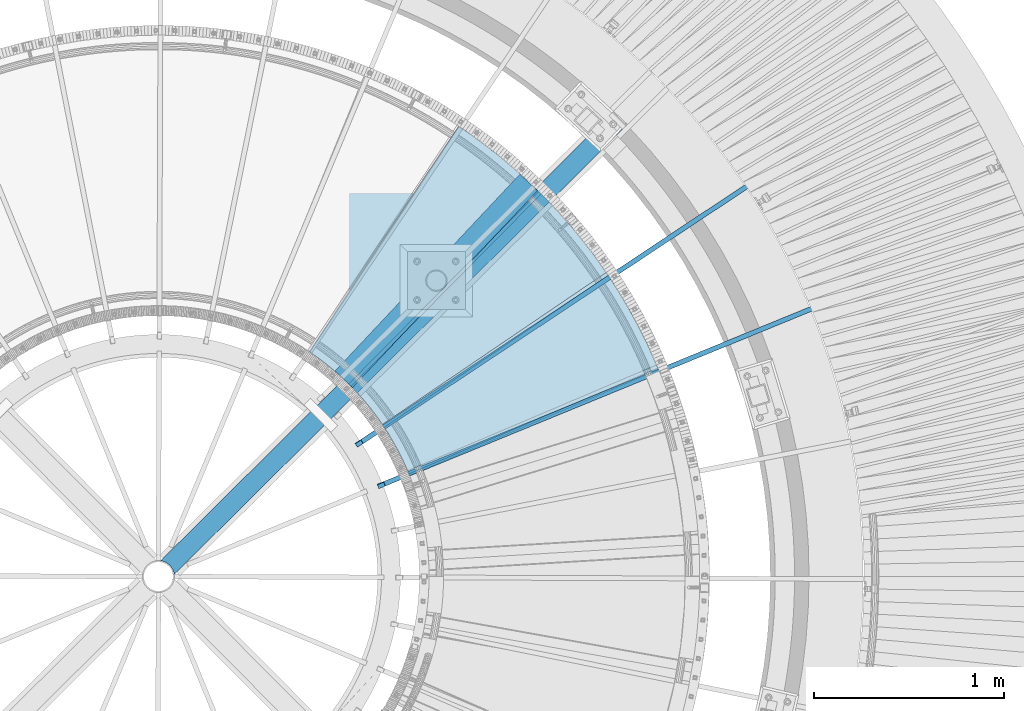
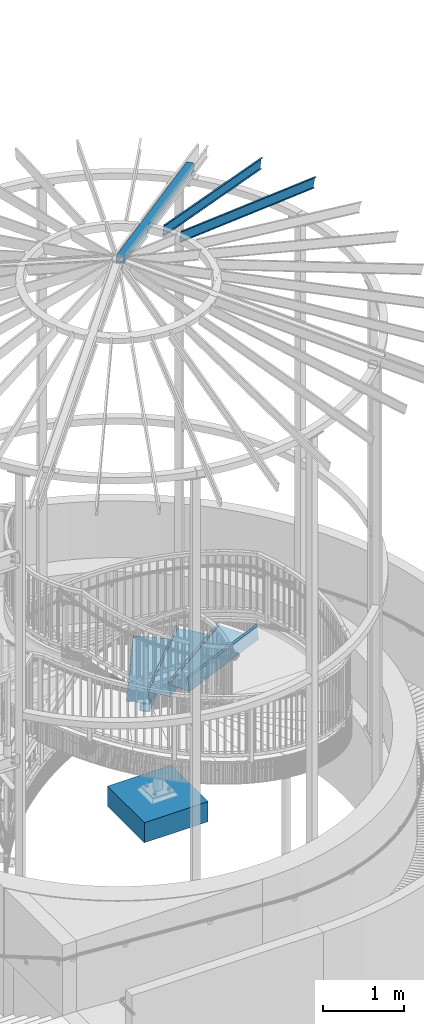
# One storey, part 366 of 975: 8 beams.
"""IFC2X3 building model written with IfcOpenShell, lengths in millimetres."""

from ifc_helpers import new_model, si_unit, frame, origin_with_axes, place, context, subcontext, project, spatial, faceted_brep, material, type_object, element, save


model = new_model("IFC2X3")

# Units and contexts
model_context = context("Model", 3, precision=1e-05, world=origin_with_axes())
body_context = subcontext(model_context, "Body", "Model", "MODEL_VIEW")
ifc_project = project(units=[si_unit("LENGTHUNIT", "METRE", prefix="MILLI"), si_unit("AREAUNIT", "SQUARE_METRE"), si_unit("VOLUMEUNIT", "CUBIC_METRE"), si_unit("MASSUNIT", "GRAM", prefix="KILO"), si_unit("TIMEUNIT", "SECOND"), si_unit("PLANEANGLEUNIT", "RADIAN"), si_unit("SOLIDANGLEUNIT", "STERADIAN"), si_unit("THERMODYNAMICTEMPERATUREUNIT", "DEGREE_CELSIUS"), si_unit("LUMINOUSINTENSITYUNIT", "LUMEN")], contexts=[model_context])

# Site, building, storey
site_placement = place(None, origin_with_axes())
site = spatial("IfcSite", under=ifc_project, at=site_placement, CompositionType="ELEMENT")
building_placement = place(site_placement, origin_with_axes())
building = spatial("IfcBuilding", under=site, at=building_placement, Name="Undefined", CompositionType="ELEMENT")
storey_placement = place(building_placement, origin_with_axes())
storey = spatial("IfcBuildingStorey", under=building, at=storey_placement, Name="Undefined", CompositionType="ELEMENT", Elevation=0.0)

# Beams
ifc_material_1 = material(Name="STEEL/A36")
beam_type_1 = type_object("IfcBeamType", PredefinedType="NOTDEFINED")
beam_1_placement = place(storey_placement, frame((36756.8557045122, 4244.42180380441, 2114.51695574219), z_axis=(0.92039398918159, 0.390992205393406, 2.91087417281233e-10), x_axis=(-0.276473240043629, 0.650816831102425, 0.707106781111294)))
element("IfcBeam", 1, at=beam_1_placement, inside=storey, type_object=beam_type_1, material=ifc_material_1, Name="TREAD", context=body_context, shape_type="Brep", body=[
    faceted_brep([(25.4000001621371, 1.5874997143419, 653.28751700326), (1.61144271260127e-08, 1.58750000026703, 653.458911680114), (-1.96268956642598e-08, -1.58749999973588, 653.437487347819), (15.8745748038546, -1.5875001784334, 653.330368544412), (-120.373022221533, -103.76749224318, 653.560250726816), (-154.208562872085, -137.603032237963, 653.560249286144), (-49.0005534961238, -242.811041643061, 652.140399877677), (-46.7554894721361, -240.565977619684, 652.140399877557), (-149.718432901582, -137.603030988068, 653.529952160912), (-118.287540217565, -106.172138299769, 653.529952144057), (82.2634121742994, -374.075007349978, 638.193006315465), (84.508476198167, -371.829943326711, 638.193006315345), (212.601306559884, -504.412901568812, 612.134347567509), (214.846370562875, -502.167837565145, 612.134347570151), (261.055176792581, -530.596712595621, 601.111823144849), (259.197053542079, -528.103470062568, 601.754434690294), (248.701623596196, -536.023091227627, 602.134831213494), (248.362633442506, -540.174228440612, 601.571851715846), (250.921725105154, -538.24319290819, 601.479100122608), (25.4000001865188, 1.58749971376164, -768.618736200977), (-118.287540216395, -106.172138302336, -768.542582766611), (-149.718433278054, -137.603031368186, -768.542582749815), (-92.8426928760819, -194.478774201189, -768.783692225286), (-95.087756899542, -196.723838224048, -768.783692225159), (-154.208562871598, -137.603032235413, -768.533065523057), (-120.373022220361, -103.767492245748, -768.533065418116), (15.8745748282345, -1.58750017901184, -768.605275732323), (-1.58015609486029e-08, -1.58750000031432, -768.571627720263), (1.99397618416697e-08, 1.58749999968677, -768.564897939472), (-21.2434099455131, -266.078057151808, -776.330856581004), (-23.4884739689005, -268.323121174595, -776.330856580884), (49.7927349215133, -337.114201961485, -791.08236047571), (47.5476709198538, -339.35926596382, -791.082360478347), (66.437802308692, -335.979336534963, -793.502619428495), (56.3071310127107, -343.628597994977, -793.115412720523), (53.7487404151489, -345.560335457225, -793.01762786691), (54.0919957188744, -341.413461775162, -792.424099714608), (64.5845451579717, -333.490960101732, -792.825137753654)], [[[0, 1, 2, 3, 4, 5, 6, 7, 8, 9]], [[7, 6, 10, 11]], [[11, 10, 12, 13]], [[14, 15, 16, 13, 12, 17, 18]], [[19, 20, 21, 22, 23, 24, 25, 26, 27, 28]], [[29, 30, 23, 22]], [[31, 32, 30, 29]], [[33, 34, 35, 32, 31, 36, 37]], [[34, 33, 14, 18]], [[35, 34, 18, 17]], [[10, 6, 5, 24, 23, 30, 32, 35, 17, 12]], [[25, 24, 5, 4]], [[26, 25, 4, 3]], [[27, 26, 3, 2]], [[28, 27, 2, 1]], [[19, 28, 1, 0]], [[20, 19, 0, 9]], [[20, 9, 8, 21]], [[36, 31, 29, 22, 21, 8, 7, 11, 13, 16]], [[37, 36, 16, 15]], [[33, 37, 15, 14]]]),
])
beam_2_placement = place(storey_placement, frame((36555.7884703483, 4620.07532202265, 1936.71695574218), z_axis=(0.827274263320992, 0.561798267393831, 1.45474359669606e-10), x_axis=(-0.397251364861499, 0.584971241795961, 0.707106780753351)))
element("IfcBeam", 2, at=beam_2_placement, inside=storey, type_object=beam_type_1, material=ifc_material_1, Name="TREAD", context=body_context, shape_type="Brep", body=[
    faceted_brep([(25.4000001621371, 1.5874997143419, 653.28751700326), (1.61144271260127e-08, 1.58750000026703, 653.458911680114), (-1.96268956642598e-08, -1.58749999973588, 653.437487347819), (15.8745748038546, -1.5875001784334, 653.330368544412), (-120.373022221533, -103.76749224318, 653.560250726816), (-154.208562872085, -137.603032237963, 653.560249286144), (-49.0005534961238, -242.811041643061, 652.140399877677), (-46.7554894721361, -240.565977619684, 652.140399877557), (-149.718432901582, -137.603030988068, 653.529952160912), (-118.287540217565, -106.172138299769, 653.529952144057), (82.2634121742994, -374.075007349978, 638.193006315465), (84.508476198167, -371.829943326711, 638.193006315345), (212.601306559884, -504.412901568812, 612.134347567509), (214.846370562875, -502.167837565145, 612.134347570151), (261.055176792581, -530.596712595621, 601.111823144849), (259.197053542079, -528.103470062568, 601.754434690294), (248.701623596196, -536.023091227627, 602.134831213494), (248.362633442506, -540.174228440612, 601.571851715846), (250.921725105154, -538.24319290819, 601.479100122608), (25.4000001865188, 1.58749971376164, -768.618736200977), (-118.287540216395, -106.172138302336, -768.542582766611), (-149.718433278054, -137.603031368186, -768.542582749815), (-92.8426928760819, -194.478774201189, -768.783692225286), (-95.087756899542, -196.723838224048, -768.783692225159), (-154.208562871598, -137.603032235413, -768.533065523057), (-120.373022220361, -103.767492245748, -768.533065418116), (15.8745748282345, -1.58750017901184, -768.605275732323), (-1.58015609486029e-08, -1.58750000031432, -768.571627720263), (1.99397618416697e-08, 1.58749999968677, -768.564897939472), (-21.2434099455131, -266.078057151808, -776.330856581004), (-23.4884739689005, -268.323121174595, -776.330856580884), (49.7927349215133, -337.114201961485, -791.08236047571), (47.5476709198538, -339.35926596382, -791.082360478347), (66.437802308692, -335.979336534963, -793.502619428495), (56.3071310127107, -343.628597994977, -793.115412720523), (53.7487404151489, -345.560335457225, -793.01762786691), (54.0919957188744, -341.413461775162, -792.424099714608), (64.5845451579717, -333.490960101732, -792.825137753654)], [[[0, 1, 2, 3, 4, 5, 6, 7, 8, 9]], [[7, 6, 10, 11]], [[11, 10, 12, 13]], [[14, 15, 16, 13, 12, 17, 18]], [[19, 20, 21, 22, 23, 24, 25, 26, 27, 28]], [[29, 30, 23, 22]], [[31, 32, 30, 29]], [[33, 34, 35, 32, 31, 36, 37]], [[34, 33, 14, 18]], [[35, 34, 18, 17]], [[10, 6, 5, 24, 23, 30, 32, 35, 17, 12]], [[25, 24, 5, 4]], [[26, 25, 4, 3]], [[27, 26, 3, 2]], [[28, 27, 2, 1]], [[19, 28, 1, 0]], [[20, 19, 0, 9]], [[20, 9, 8, 21]], [[36, 31, 29, 22, 21, 8, 7, 11, 13, 16]], [[37, 36, 16, 15]], [[33, 37, 15, 14]]]),
])
beam_3_placement = place(storey_placement, frame((36285.7927623504, 4949.69012247729, 1758.91695574218), z_axis=(0.702845519800045, 0.711342516160116, 2.54775613939273e-10), x_axis=(-0.502995117091272, 0.496986833090081, 0.707106781128161)))
element("IfcBeam", 3, at=beam_3_placement, inside=storey, type_object=beam_type_1, material=ifc_material_1, Name="TREAD", context=body_context, shape_type="Brep", body=[
    faceted_brep([(25.4000001621371, 1.5874997143419, 653.28751700326), (1.61144271260127e-08, 1.58750000026703, 653.458911680114), (-1.96268956642598e-08, -1.58749999973588, 653.437487347819), (15.8745748038546, -1.5875001784334, 653.330368544412), (-120.373022221533, -103.76749224318, 653.560250726816), (-154.208562872085, -137.603032237963, 653.560249286144), (-49.0005534961238, -242.811041643061, 652.140399877677), (-46.7554894721361, -240.565977619684, 652.140399877557), (-149.718432901582, -137.603030988068, 653.529952160912), (-118.287540217565, -106.172138299769, 653.529952144057), (82.2634121742994, -374.075007349978, 638.193006315465), (84.508476198167, -371.829943326711, 638.193006315345), (212.601306559884, -504.412901568812, 612.134347567509), (214.846370562875, -502.167837565145, 612.134347570151), (261.055176792581, -530.596712595621, 601.111823144849), (259.197053542079, -528.103470062568, 601.754434690294), (248.701623596196, -536.023091227627, 602.134831213494), (248.362633442506, -540.174228440612, 601.571851715846), (250.921725105154, -538.24319290819, 601.479100122608), (25.4000001865188, 1.58749971376164, -768.618736200977), (-118.287540216395, -106.172138302336, -768.542582766611), (-149.718433278054, -137.603031368186, -768.542582749815), (-92.8426928760819, -194.478774201189, -768.783692225286), (-95.087756899542, -196.723838224048, -768.783692225159), (-154.208562871598, -137.603032235413, -768.533065523057), (-120.373022220361, -103.767492245748, -768.533065418116), (15.8745748282345, -1.58750017901184, -768.605275732323), (-1.58015609486029e-08, -1.58750000031432, -768.571627720263), (1.99397618416697e-08, 1.58749999968677, -768.564897939472), (-21.2434099455131, -266.078057151808, -776.330856581004), (-23.4884739689005, -268.323121174595, -776.330856580884), (49.7927349215133, -337.114201961485, -791.08236047571), (47.5476709198538, -339.35926596382, -791.082360478347), (66.437802308692, -335.979336534963, -793.502619428495), (56.3071310127107, -343.628597994977, -793.115412720523), (53.7487404151489, -345.560335457225, -793.01762786691), (54.0919957188744, -341.413461775162, -792.424099714608), (64.5845451579717, -333.490960101732, -792.825137753654)], [[[0, 1, 2, 3, 4, 5, 6, 7, 8, 9]], [[7, 6, 10, 11]], [[11, 10, 12, 13]], [[14, 15, 16, 13, 12, 17, 18]], [[19, 20, 21, 22, 23, 24, 25, 26, 27, 28]], [[29, 30, 23, 22]], [[31, 32, 30, 29]], [[33, 34, 35, 32, 31, 36, 37]], [[34, 33, 14, 18]], [[35, 34, 18, 17]], [[10, 6, 5, 24, 23, 30, 32, 35, 17, 12]], [[25, 24, 5, 4]], [[26, 25, 4, 3]], [[27, 26, 3, 2]], [[28, 27, 2, 1]], [[19, 28, 1, 0]], [[20, 19, 0, 9]], [[20, 9, 8, 21]], [[36, 31, 29, 22, 21, 8, 7, 11, 13, 16]], [[37, 36, 16, 15]], [[33, 37, 15, 14]]]),
])
ifc_material_2 = material()
beam_type_2 = type_object("IfcBeamType", Name="HSS4X4X3/8", PredefinedType="NOTDEFINED")
beam_4_placement = place(storey_placement, frame((37151.0655148666, 5802.5213526447, 8355.32707211838), z_axis=(0.17213026717781, 0.170873527176511, 0.970140922150774), x_axis=(-0.688502112820794, -0.683475127155158, 0.242541936995532)))
element("IfcBeam", 4, at=beam_4_placement, inside=storey, type_object=beam_type_2, material=ifc_material_2, Name="BEAM", ObjectType="HSS4X4X3/8", context=body_context, shape_type="Brep", body=[
    faceted_brep([(3438.83735812861, -22.0904176136246, 50.8000000013358), (3436.45604228348, -22.0904176085714, 41.2750000013289), (3433.41640701447, -0.308512534764304, 41.2750000013234), (3435.7977228596, -0.308512539817457, 50.8000000013285), (3436.29143033248, 21.4944170195777, 41.2750000013198), (3438.6727461776, 21.4944170145209, 50.8000000013249), (3454.30560025219, 50.8000000042775, 50.8000000013267), (3447.2664999947, 41.8325374313063, 50.8000000013249), (3421.8657976467, 41.8325374852029, -50.7999999987392), (3428.90489786185, 50.800000004263, -50.7999999987383), (3444.64959996888, 41.2750000042688, 41.275000001317), (3424.01152929259, 41.2750000042543, -41.274999998735), (3415.65335967472, 21.4944170633644, -41.2749999987323), (3413.27204382959, 21.4944170684175, -50.7999999987373), (3412.77833635671, -0.308512490973953, -41.2749999987295), (3410.39702051158, -0.308512485920801, -50.7999999987355), (3415.81797162572, -22.0904175647811, -41.2749999987223), (3413.43665578059, -22.0904175597279, -50.7999999987301), (3454.30536256338, -50.7999999956992, 50.8000000013449), (3428.90466025831, -50.7999999957137, -50.7999999987182), (3422.18380351628, -42.3668973185268, -50.7999999987219), (3447.58450586428, -42.3668973724198, 50.8000000013403), (3424.09408161953, -41.2749999957268, -41.2749999987177), (3444.7321522584, -41.2749999957123, 41.2750000013343), (6.3499999872256, 50.7999999999884, 50.8000000000225), (6.35000001109802, -50.799999999992, 50.8000000000425), (6.34999999362844, -50.7999999999738, -50.8000000000134), (6.34999996975966, 50.8000000000065, -50.8000000000334), (6.34999998782587, 41.2749999999942, 41.2750000000183), (6.35000000721993, -41.2749999999905, 41.2750000000347), (6.34999999302818, -41.274999999976, -41.2750000000101), (6.34999997363047, 41.2750000000087, -41.2750000000256)], [[[0, 1, 2, 3]], [[3, 2, 4, 5]], [[6, 7, 8, 9]], [[5, 4, 10, 11, 12, 13, 8, 7]], [[14, 15, 13, 12]], [[16, 17, 15, 14]], [[18, 19, 20, 21]], [[21, 20, 17, 16, 22, 23, 1, 0]], [[0, 3, 5, 7, 6, 24, 25, 18, 21]], [[26, 27, 9, 8, 13, 15, 17, 20, 19]], [[25, 26, 19, 18]], [[27, 24, 6, 9]], [[26, 25, 24, 27], [28, 29, 30, 31]], [[30, 29, 23, 22]], [[14, 12, 11, 31, 30, 22, 16]], [[28, 31, 11, 10]], [[29, 28, 10, 4, 2, 1, 23]]]),
])
beam_type_3 = type_object("IfcBeamType", Name="HSS5X5X3/8", PredefinedType="NOTDEFINED")
beam_5_placement = place(storey_placement, frame((35708.4026000066, 4440.34071961208, 1489.075), z_axis=(0.0, 0.0, 1.0), x_axis=(0.68467346590197, 0.728849946895645, 0.0)))
element("IfcBeam", 5, at=beam_5_placement, inside=storey, type_object=beam_type_3, material=ifc_material_2, Name="BEAM", ObjectType="HSS5X5X3/8", context=body_context, shape_type="Brep", body=[
    faceted_brep([(1.30967237055302e-10, 53.9749999998749, -53.9749999999999), (-1.20053300634027e-10, -53.9749999998712, -53.9749999999999), (1419.67377982074, -53.9750000024942, -53.9749999999999), (1419.67377982099, 53.9749999972482, -53.9749999999999), (-1.20053300634027e-10, -53.9749999998712, 53.9749999999999), (1419.67377982074, -53.9750000024942, 53.9749999999999), (1.30967237055302e-10, 53.9749999998749, 53.9749999999999), (1419.67377982099, 53.9749999972482, 53.9749999999999), (1.56433088704944e-10, 63.4999999998508, -63.5), (1.56433088704944e-10, 63.4999999998508, 63.5), (1419.67377982102, 63.4999999972242, 63.5), (1419.67377982102, 63.4999999972242, -63.5), (-1.45519152283669e-10, -63.4999999998436, 63.5), (1419.67377982072, -63.5000000024702, 63.5), (-1.45519152283669e-10, -63.4999999998436, -63.5), (1419.67377982072, -63.5000000024702, -63.5)], [[[0, 1, 2, 3]], [[1, 4, 5, 2]], [[4, 6, 7, 5]], [[6, 0, 3, 7]], [[8, 9, 10, 11]], [[9, 12, 13, 10]], [[12, 14, 15, 13]], [[14, 8, 11, 15]], [[13, 15, 11, 10], [5, 7, 3, 2]], [[14, 12, 9, 8], [6, 4, 1, 0]]]),
])
ifc_material_3 = material(Name="STEEL/Zero_Density")
beam_type_4 = type_object("IfcBeamType", PredefinedType="NOTDEFINED")
for number, where, z_axis, x_axis, name in (
    (6, (35789.1997368055, 4103.16772775325, 8885.0313138005), (0.202158604335491, 0.134009290222394, 0.970140922148539), (0.808612057787423, 0.536022339859085, -0.242541936936238), "STUD"),
    (7, (35905.4128703835, 3883.96401874181, 8885.0313138005), (0.224418098973874, 0.0919951519892898, 0.970140922167197), (0.897647574487811, 0.367970434790039, -0.242541936861608), "STUD"),
):
    element("IfcBeam", number, at=place(storey_placement, frame(where, z_axis=z_axis, x_axis=x_axis)), inside=storey, type_object=beam_type_4, material=ifc_material_3, Name=name, context=body_context, shape_type="Brep", body=[
        faceted_brep([(-1.67347025126219e-10, 12.6999999998588, -76.2000000000985), (1.96450855582952e-10, 12.7000000001644, 76.2000000001021), (2798.98467503002, 12.7000000041553, 76.2000000028588), (2798.98467502966, 12.7000000038533, -76.1999999973427), (1.74622982740402e-10, -12.6999999998661, 76.2000000000985), (2798.98467503, -12.6999999958753, 76.2000000028534), (1.67347025126219e-10, -12.6999999998698, 73.0250000000947), (2798.98467502999, -12.6999999958789, 73.0250000028504), (1.89174897968769e-10, 9.52500000015425, 73.0250000000974), (2798.98467503001, 9.52500000414511, 73.0250000028532), (-1.60071067512035e-10, 9.52499999986321, -73.0250000000938), (2798.98467502966, 9.52500000385407, -73.0249999973398), (-1.81898940354586e-10, -12.7000000001608, -73.0250000000965), (2798.98467502964, -12.6999999961699, -73.0249999973416), (-1.92812876775861e-10, -12.7000000001717, -76.2000000001003), (2798.98467502963, -12.6999999961772, -76.1999999973455)], [[[0, 1, 2, 3]], [[1, 4, 5, 2]], [[4, 6, 7, 5]], [[6, 8, 9, 7]], [[8, 10, 11, 9]], [[10, 12, 13, 11]], [[12, 14, 15, 13]], [[14, 0, 3, 15]], [[5, 7, 9, 11, 13, 15, 3, 2]], [[14, 12, 10, 8, 6, 4, 1, 0]]]),
    ])
ifc_material_4 = material(Name="CONCRETE/5000")
beam_type_5 = type_object("IfcBeamType", PredefinedType="NOTDEFINED")
beam_6_placement = place(storey_placement, frame((35738.1595913399, 4958.69262568473, -457.2), z_axis=(0.0, 0.0, 1.0), x_axis=(1.0, 0.0, 0.0)))
element("IfcBeam", 8, at=beam_6_placement, inside=storey, type_object=beam_type_5, material=ifc_material_4, Name="FOOTING", context=body_context, shape_type="Brep", body=[
    faceted_brep([(0.0, 457.2, -152.4), (0.0, 457.2, 152.4), (914.400000000001, 457.2, 152.4), (914.400000000001, 457.2, -152.4), (0.0, -457.2, 152.4), (914.400000000001, -457.2, 152.4), (0.0, -457.2, -152.4), (914.400000000001, -457.2, -152.4)], [[[0, 1, 2, 3]], [[1, 4, 5, 2]], [[4, 6, 7, 5]], [[6, 0, 3, 7]], [[5, 7, 3, 2]], [[6, 4, 1, 0]]]),
])

save(model, "model.ifc")
